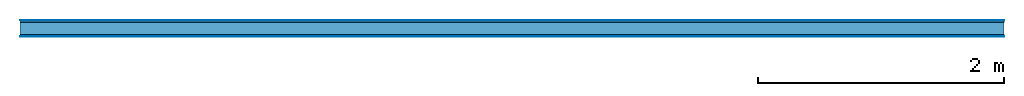
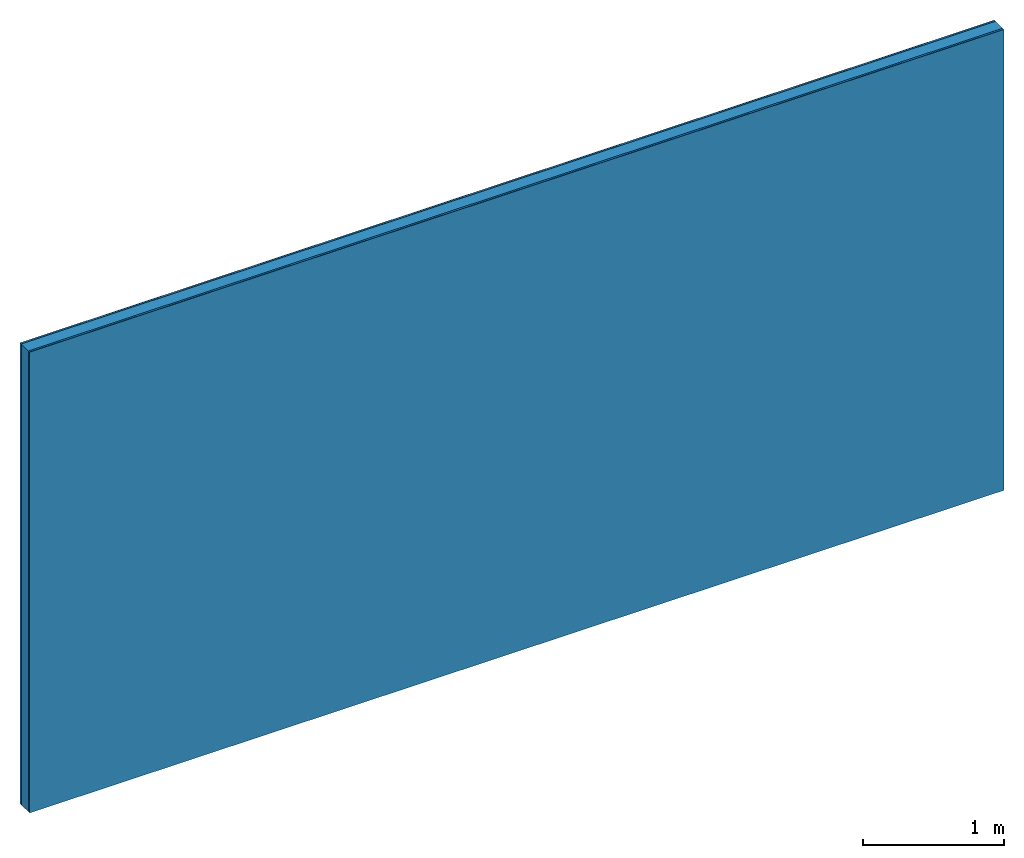
# One storey: 4 plates, 1 member, 1 element without a shape of its own.
"""IFC4 building model written with IfcOpenShell, lengths in metres."""

import ifcopenshell
import ifcopenshell.guid

model = None  # the IFC model being written
_history = None  # IfcOwnerHistory: only IFC2X3 demands one
_inside = {}  # id of a spatial element -> (the spatial element, [elements in it])
_under = {}  # id of a project, library or spatial element -> (it, [spatial elements below it])
_declared = {}  # id of a project -> (the project, [libraries it declares])
_typed = {}  # id of a type object -> (the type object, [elements of that type])
_made_of = {}  # id of a material, layer set ... -> (it, [elements and type objects made of it])


def new_model(schema):
    """Start an empty IFC model of exactly this schema.

    Asked for "IFC4X3", IfcOpenShell would pick the latest addendum, in which some entities
    have other attributes; the version numbers below select the first issue.
    IFC2X3 requires an IfcOwnerHistory on every rooted entity: one is made here for all.
    """
    global model, _history
    if schema == "IFC4X3":
        model = ifcopenshell.file(schema_version=(4, 3, 0, 0))
    else:
        model = ifcopenshell.file(schema=schema)
    _inside.clear()
    _under.clear()
    _declared.clear()
    _typed.clear()
    _made_of.clear()
    _history = None
    if model.schema == "IFC2X3":
        org = make("IfcOrganization", Name="unknown")
        user = make(
            "IfcPersonAndOrganization",
            ThePerson=make("IfcPerson", FamilyName="unknown"),
            TheOrganization=org,
        )
        app = make(
            "IfcApplication",
            ApplicationDeveloper=org,
            Version="unknown",
            ApplicationFullName="unknown",
            ApplicationIdentifier="unknown",
        )
        _history = make(
            "IfcOwnerHistory",
            OwningUser=user,
            OwningApplication=app,
            ChangeAction="ADDED",
            CreationDate=0,
        )
    return model


def make(cls, **values):
    """One entity of the class cls with the attributes given. An attribute that is None is left unset."""
    return model.create_entity(
        cls, **{name: value for name, value in values.items() if value is not None}
    )


def rooted(cls, **values):
    """An entity with a GlobalId (a new one), such as an element, a storey or a relation."""
    return make(cls, GlobalId=ifcopenshell.guid.new(), OwnerHistory=_history, **values)


def si_unit(unit_type, name, prefix=None):
    """IfcSIUnit, for example si_unit("LENGTHUNIT", "METRE", prefix="MILLI")."""
    return make("IfcSIUnit", UnitType=unit_type, Prefix=prefix, Name=name)


def derived_unit(unit_type, elements):
    """IfcDerivedUnit: a product of units, each with its exponent."""
    return make(
        "IfcDerivedUnit",
        Elements=[
            make("IfcDerivedUnitElement", Unit=unit, Exponent=power)
            for unit, power in elements
        ],
        UnitType=unit_type,
    )


def assignment(units):
    """IfcUnitAssignment: the units of a project."""
    return None if units is None else make("IfcUnitAssignment", Units=units)


def point(xyz):
    """IfcCartesianPoint."""
    return None if xyz is None else make("IfcCartesianPoint", Coordinates=xyz)


def direction(xyz):
    """IfcDirection."""
    return None if xyz is None else make("IfcDirection", DirectionRatios=xyz)


def frame(location, z_axis=None, x_axis=None):
    """IfcAxis2Placement3D, a coordinate frame: its origin and axes. An axis left out is left unset."""
    return make(
        "IfcAxis2Placement3D",
        Location=point(location),
        Axis=direction(z_axis),
        RefDirection=direction(x_axis),
    )


def frame_2d(location, x_axis=None):
    """IfcAxis2Placement2D, a coordinate frame in the plane: its origin and x axis."""
    return make(
        "IfcAxis2Placement2D", Location=point(location), RefDirection=direction(x_axis)
    )


def origin():
    """The frame at (0, 0, 0) with its axes left unset."""
    return frame((0.0, 0.0, 0.0))


def origin_with_axes():
    """The frame at (0, 0, 0) with the z axis (0, 0, 1) and the x axis (1, 0, 0) written out."""
    return frame((0.0, 0.0, 0.0), z_axis=(0.0, 0.0, 1.0), x_axis=(1.0, 0.0, 0.0))


def place(relative_to, where):
    """IfcLocalPlacement: puts the frame where relative to a parent placement (None: the world)."""
    return make(
        "IfcLocalPlacement", PlacementRelTo=relative_to, RelativePlacement=where
    )


def context(
    kind, dimensions, precision=None, world=None, true_north=None, identifier=None
):
    """IfcGeometricRepresentationContext, for example the 3D "Model" context."""
    return make(
        "IfcGeometricRepresentationContext",
        ContextIdentifier=identifier,
        ContextType=kind,
        CoordinateSpaceDimension=dimensions,
        Precision=precision,
        WorldCoordinateSystem=world,
        TrueNorth=true_north,
    )


def project(units=None, contexts=None):
    """IfcProject with its units and contexts."""
    return rooted(
        "IfcProject",
        Name="project",
        RepresentationContexts=contexts,
        UnitsInContext=assignment(units),
    )


def spatial(cls, under=None, at=None, **own):
    """A site, building, storey or space (cls), placed at a placement, below another one or the project."""
    s = rooted(cls, ObjectPlacement=at, **own)
    if under is not None:
        _under.setdefault(under.id(), (under, []))[1].append(s)
    return s


def profile(cls, at=None, kind="AREA", **sizes):
    """A parametric profile (cls). Its sizes go by their IFC names, for example OverallWidth=200.0."""
    return make(cls, ProfileType=kind, Position=at, **sizes)


def rectangle(**sizes):
    """IfcRectangleProfileDef."""
    return profile("IfcRectangleProfileDef", **sizes)


def extrude(swept, where, along, depth):
    """IfcExtrudedAreaSolid: the profile swept, set in the frame where, extruded along a direction by depth."""
    return make(
        "IfcExtrudedAreaSolid",
        SweptArea=swept,
        Position=where,
        ExtrudedDirection=direction(along),
        Depth=depth,
    )


def shape(context_of_items, identifier, shape_type, items):
    """IfcShapeRepresentation: the items that make up one representation, for example the "Body"."""
    return make(
        "IfcShapeRepresentation",
        ContextOfItems=context_of_items,
        RepresentationIdentifier=identifier,
        RepresentationType=shape_type,
        Items=items,
    )


def material(Name=None, Category=None):
    """IfcMaterial."""
    return make("IfcMaterial", Name=Name, Category=Category)


def layer(
    of_material, thickness, ventilated=None, Name=None, Category=None, Priority=None
):
    """IfcMaterialLayer: one layer of a wall or slab, of a material (None: an air gap)."""
    return make(
        "IfcMaterialLayer",
        Material=of_material,
        LayerThickness=thickness,
        IsVentilated=ventilated,
        Name=Name,
        Category=Category,
        Priority=Priority,
    )


def layer_set(layers, Name=None):
    """IfcMaterialLayerSet."""
    return make("IfcMaterialLayerSet", MaterialLayers=layers, LayerSetName=Name)


def made_of(thing, what):
    """Note that an element or type object is made of a material, layer set ...; save() writes the relation."""
    if what is not None:
        _made_of.setdefault(what.id(), (what, []))[1].append(thing)
    return thing


def type_object(cls, material=None, **own):
    """A type object (cls), such as IfcWallType, which elements share."""
    return made_of(rooted(cls, **own), material)


def element(
    cls,
    number,
    at=None,
    inside=None,
    cuts=None,
    type_object=None,
    material=None,
    context=None,
    identifier="Body",
    shape_type=None,
    held_by="IfcProductDefinitionShape",
    body=None,
    shapes=None,
    **own,
):
    """One element of the class cls, such as IfcWall. Its Tag is "e" and its number.

    at: its placement. inside: the storey or other place that contains it. cuts: it is an
    opening in that element (IfcRelVoidsElement). A single representation is given by context,
    identifier, shape_type and body (its items); several are given by shapes. held_by: the class
    of the entity that holds the representations. save() writes the other relations.
    """
    e = rooted(cls, Tag="e%d" % number, ObjectPlacement=at, **own)
    if body is not None:
        shapes = [shape(context, identifier, shape_type, body)]
    if shapes is not None:
        e.Representation = make(held_by, Representations=shapes)
    if inside is not None:
        _inside.setdefault(inside.id(), (inside, []))[1].append(e)
    if cuts is not None:
        rooted(
            "IfcRelVoidsElement", RelatingBuildingElement=cuts, RelatedOpeningElement=e
        )
    if type_object is not None:
        _typed.setdefault(type_object.id(), (type_object, []))[1].append(e)
    return made_of(e, material)


def aggregate(whole, parts):
    """IfcRelAggregates: a whole, such as a stair, and the parts it consists of."""
    return rooted("IfcRelAggregates", RelatingObject=whole, RelatedObjects=parts)


def save(model, path):
    """Write the relations noted so far, then the file.

    IfcRelAggregates (storeys below a building ...), IfcRelContainedInSpatialStructure (elements
    in a storey), IfcRelDefinesByType, IfcRelAssociatesMaterial and IfcRelDeclares: one each for
    every whole, place, type object, material and project.
    """
    for whole, parts in _under.values():
        aggregate(whole, parts)
    for where, things in _inside.values():
        rooted(
            "IfcRelContainedInSpatialStructure",
            RelatedElements=things,
            RelatingStructure=where,
        )
    for kind, things in _typed.values():
        rooted("IfcRelDefinesByType", RelatedObjects=things, RelatingType=kind)
    for what, things in _made_of.values():
        rooted("IfcRelAssociatesMaterial", RelatedObjects=things, RelatingMaterial=what)
    for by, libraries in _declared.values():
        rooted("IfcRelDeclares", RelatingContext=by, RelatedDefinitions=libraries)
    model.write(path)


model = new_model("IFC4")

# Units and contexts
plan_context = context("Plan", 3, precision=1e-05, world=origin(), true_north=direction((0.0, 1.0)))
model_context = context("Model", 3, precision=1e-05, world=origin(), true_north=direction((0.0, 1.0)))
ifc_project = project(units=[si_unit("LENGTHUNIT", "METRE"), derived_unit("SOUNDPRESSUREUNIT", [(si_unit("PRESSUREUNIT", "PASCAL", prefix="MICRO"), 0)]), si_unit("ENERGYUNIT", "JOULE", prefix="MEGA"), si_unit("MASSUNIT", "GRAM", prefix="KILO"), derived_unit("THERMALTRANSMITTANCEUNIT", [(si_unit("POWERUNIT", "WATT"), 1), (si_unit("AREAUNIT", "SQUARE_METRE"), -1), (si_unit("THERMODYNAMICTEMPERATUREUNIT", "KELVIN"), -1)]), derived_unit("AREADENSITYUNIT", [(si_unit("MASSUNIT", "GRAM", prefix="KILO"), 1), (si_unit("AREAUNIT", "SQUARE_METRE"), -1)]), derived_unit("USERDEFINED", [(si_unit("ENERGYUNIT", "JOULE", prefix="MEGA"), 1), (si_unit("AREAUNIT", "SQUARE_METRE"), -1)])], contexts=[plan_context, model_context])

# Site, building, storey
site = spatial("IfcSite", under=ifc_project)
building_placement = place(None, origin())
building = spatial("IfcBuilding", under=site, at=building_placement)
storey_placement = place(building_placement, origin())
storey = spatial("IfcBuildingStorey", under=building, at=storey_placement)

# Wall, member, plates
ifc_material_1 = material(Category="04.001")
ifc_layer_1 = layer(ifc_material_1, 0.003, Name="Surface")
ifc_material_2 = material(Name="DFH2IR Knauf Diamant hard- plasterboard", Category="03.007")
ifc_layer_2 = layer(ifc_material_2, 0.015, Name="1st layer")
ifc_material_3 = material(Name="of the art")
ifc_layer_3 = layer(ifc_material_3, 0.0, Name="Bond")
ifc_layer_4 = layer(None, 0.1, Name="Support")
ifc_layer_5 = layer(ifc_material_3, 0.0, Name="Bond")
ifc_layer_6 = layer(ifc_material_2, 0.015, Name="1st layer")
ifc_layer_7 = layer(ifc_material_1, 0.003, Name="Surface")
ifc_layer_set = layer_set([ifc_layer_1, ifc_layer_2, ifc_layer_3, ifc_layer_4, ifc_layer_5, ifc_layer_6, ifc_layer_7])
wall_type = type_object("IfcWallType", Name="C0372", PredefinedType="NOTDEFINED", material=ifc_layer_set)
wall_placement = place(None, frame((0.0, 0.0, 0.0), z_axis=(0.0, -1.0, 0.0), x_axis=(1.0, 0.0, 0.0)))
wall = element("IfcWall", 1, at=wall_placement, inside=storey, type_object=wall_type, material=ifc_layer_set, Name="Wall #1")
ifc_material_4 = material(Name="Solid timber panel")
member_placement = place(wall_placement, origin())
member = element("IfcMember", 2, at=member_placement, material=ifc_material_4, Name="Support", context=plan_context, shape_type="SweptSolid", body=[
    extrude(rectangle(XDim=1.0, YDim=0.1, at=frame_2d((0.5, 0.05), x_axis=(1.0, 0.0))), frame((0.0, 4.0, 0.018), z_axis=(0.0, -1.0, 0.0), x_axis=(1.0, 0.0, 0.0)), (0.0, 0.0, 1.0), 4.0),
    extrude(rectangle(XDim=1.0, YDim=0.1, at=frame_2d((0.5, 0.05), x_axis=(1.0, 0.0))), frame((1.0, 4.0, 0.018), z_axis=(0.0, -1.0, 0.0), x_axis=(1.0, 0.0, 0.0)), (0.0, 0.0, 1.0), 4.0),
    extrude(rectangle(XDim=1.0, YDim=0.1, at=frame_2d((0.5, 0.05), x_axis=(1.0, 0.0))), frame((2.0, 4.0, 0.018), z_axis=(0.0, -1.0, 0.0), x_axis=(1.0, 0.0, 0.0)), (0.0, 0.0, 1.0), 4.0),
    extrude(rectangle(XDim=1.0, YDim=0.1, at=frame_2d((0.5, 0.05), x_axis=(1.0, 0.0))), frame((3.0, 4.0, 0.018), z_axis=(0.0, -1.0, 0.0), x_axis=(1.0, 0.0, 0.0)), (0.0, 0.0, 1.0), 4.0),
    extrude(rectangle(XDim=1.0, YDim=0.1, at=frame_2d((0.5, 0.05), x_axis=(1.0, 0.0))), frame((4.0, 4.0, 0.018), z_axis=(0.0, -1.0, 0.0), x_axis=(1.0, 0.0, 0.0)), (0.0, 0.0, 1.0), 4.0),
    extrude(rectangle(XDim=1.0, YDim=0.1, at=frame_2d((0.5, 0.05), x_axis=(1.0, 0.0))), frame((5.0, 4.0, 0.018), z_axis=(0.0, -1.0, 0.0), x_axis=(1.0, 0.0, 0.0)), (0.0, 0.0, 1.0), 4.0),
    extrude(rectangle(XDim=1.0, YDim=0.1, at=frame_2d((0.5, 0.05), x_axis=(1.0, 0.0))), frame((6.0, 4.0, 0.018), z_axis=(0.0, -1.0, 0.0), x_axis=(1.0, 0.0, 0.0)), (0.0, 0.0, 1.0), 4.0),
    extrude(rectangle(XDim=1.0, YDim=0.1, at=frame_2d((0.5, 0.05), x_axis=(1.0, 0.0))), frame((7.0, 4.0, 0.018), z_axis=(0.0, -1.0, 0.0), x_axis=(1.0, 0.0, 0.0)), (0.0, 0.0, 1.0), 4.0),
])
plate_1_placement = place(wall_placement, origin())
plate_1 = element("IfcPlate", 3, at=plate_1_placement, material=ifc_material_1, Name="Surface", context=plan_context, shape_type="SweptSolid", body=[
    extrude(rectangle(XDim=8.0, YDim=4.0, at=frame_2d((4.0, 2.0), x_axis=(1.0, 0.0))), origin_with_axes(), (0.0, 0.0, 1.0), 0.003),
])
plate_2_placement = place(wall_placement, origin())
plate_2 = element("IfcPlate", 4, at=plate_2_placement, material=ifc_material_2, Name="1st layer", context=plan_context, shape_type="SweptSolid", body=[
    extrude(rectangle(XDim=8.0, YDim=4.0, at=frame_2d((4.0, 2.0), x_axis=(1.0, 0.0))), frame((0.0, 0.0, 0.003), z_axis=(0.0, 0.0, 1.0), x_axis=(1.0, 0.0, 0.0)), (0.0, 0.0, 1.0), 0.015),
])
plate_3_placement = place(wall_placement, origin())
plate_3 = element("IfcPlate", 5, at=plate_3_placement, material=ifc_material_2, Name="1st layer", context=plan_context, shape_type="SweptSolid", body=[
    extrude(rectangle(XDim=8.0, YDim=4.0, at=frame_2d((4.0, 2.0), x_axis=(1.0, 0.0))), frame((0.0, 0.0, 0.118), z_axis=(0.0, 0.0, 1.0), x_axis=(1.0, 0.0, 0.0)), (0.0, 0.0, 1.0), 0.015),
])
plate_4_placement = place(wall_placement, origin())
plate_4 = element("IfcPlate", 6, at=plate_4_placement, material=ifc_material_1, Name="Surface", context=plan_context, shape_type="SweptSolid", body=[
    extrude(rectangle(XDim=8.0, YDim=4.0, at=frame_2d((4.0, 2.0), x_axis=(1.0, 0.0))), frame((0.0, 0.0, 0.133), z_axis=(0.0, 0.0, 1.0), x_axis=(1.0, 0.0, 0.0)), (0.0, 0.0, 1.0), 0.003),
])
aggregate(wall, [plate_1, plate_2, member, plate_3, plate_4])

save(model, "model.ifc")
